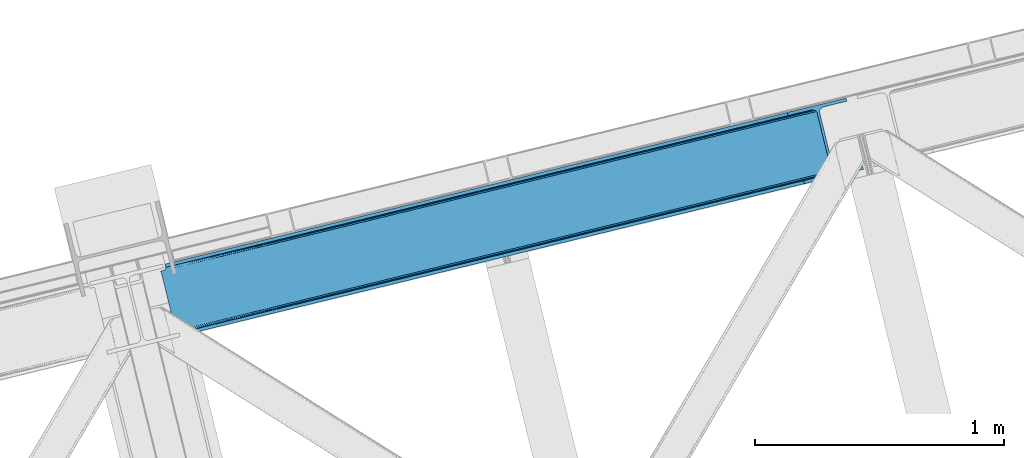
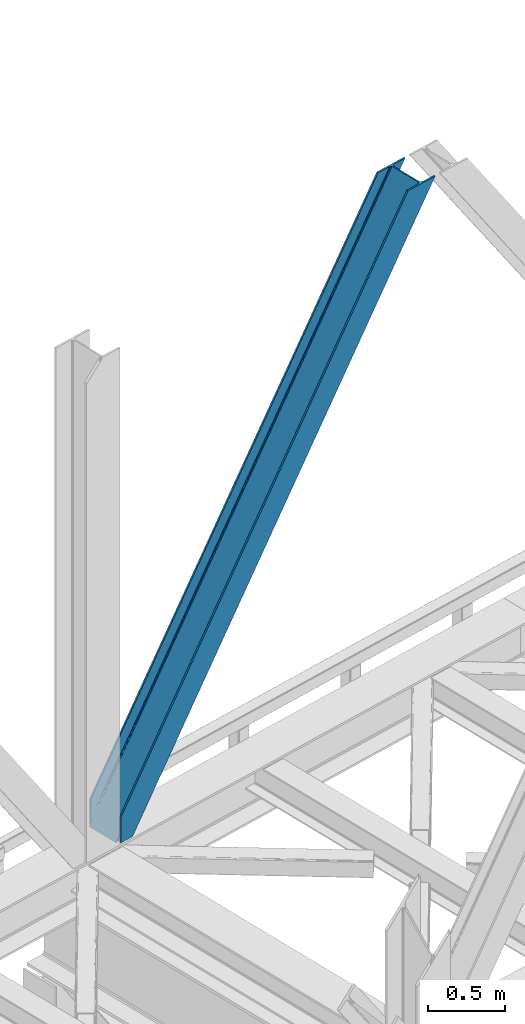
# One storey, part 33 of 92: 1 member.
"""IFC4 building model written with IfcOpenShell, lengths in millimetres."""

from ifc_helpers import new_model, entity, si_unit, converted_unit, derived_unit, direction, frame, origin, place, context, subcontext, project, spatial, triangles, type_object, element, save


model = new_model("IFC4")

# Units and contexts
model_context = context("Model", 3, precision=0.01, world=origin(), true_north=direction((6.12303176911189e-17, 1.0)))
plan_context = context("Plan", 3, precision=0.01, world=origin(), true_north=direction((6.12303176911189e-17, 1.0)))
body_context = subcontext(model_context, "Body", "Model", "MODEL_VIEW")
ifc_project = project(units=[si_unit("LENGTHUNIT", "METRE", prefix="MILLI"), si_unit("AREAUNIT", "SQUARE_METRE"), si_unit("VOLUMEUNIT", "CUBIC_METRE"), converted_unit("PLANEANGLEUNIT", "DEGREE", entity("IfcRatioMeasure", 0.0174532925199433), si_unit("PLANEANGLEUNIT", "RADIAN"), dimensions=[0, 0, 0, 0, 0, 0, 0]), si_unit("MASSUNIT", "GRAM", prefix="KILO"), derived_unit("MASSDENSITYUNIT", [(si_unit("MASSUNIT", "GRAM", prefix="KILO"), 1), (si_unit("LENGTHUNIT", "METRE"), -3)]), derived_unit("MOMENTOFINERTIAUNIT", [(si_unit("LENGTHUNIT", "METRE"), 4)]), si_unit("TIMEUNIT", "SECOND"), si_unit("FREQUENCYUNIT", "HERTZ"), si_unit("THERMODYNAMICTEMPERATUREUNIT", "DEGREE_CELSIUS"), derived_unit("THERMALTRANSMITTANCEUNIT", [(si_unit("MASSUNIT", "GRAM", prefix="KILO"), 1), (si_unit("THERMODYNAMICTEMPERATUREUNIT", "KELVIN"), -1), (si_unit("TIMEUNIT", "SECOND"), -3)]), derived_unit("VOLUMETRICFLOWRATEUNIT", [(si_unit("LENGTHUNIT", "METRE"), 3), (si_unit("TIMEUNIT", "SECOND"), -1)]), derived_unit("MASSFLOWRATEUNIT", [(si_unit("MASSUNIT", "GRAM", prefix="KILO"), 1), (si_unit("TIMEUNIT", "SECOND"), -1)]), derived_unit("ROTATIONALFREQUENCYUNIT", [(si_unit("TIMEUNIT", "SECOND"), -1)]), si_unit("ELECTRICCURRENTUNIT", "AMPERE"), si_unit("ELECTRICVOLTAGEUNIT", "VOLT"), si_unit("POWERUNIT", "WATT"), si_unit("FORCEUNIT", "NEWTON", prefix="KILO"), si_unit("ILLUMINANCEUNIT", "LUX"), si_unit("LUMINOUSFLUXUNIT", "LUMEN"), si_unit("LUMINOUSINTENSITYUNIT", "CANDELA"), derived_unit("USERDEFINED", [(si_unit("MASSUNIT", "GRAM", prefix="KILO"), -1), (si_unit("LENGTHUNIT", "METRE"), -2), (si_unit("TIMEUNIT", "SECOND"), 3), (si_unit("LUMINOUSFLUXUNIT", "LUMEN"), 1)]), derived_unit("LINEARVELOCITYUNIT", [(si_unit("LENGTHUNIT", "METRE"), 1), (si_unit("TIMEUNIT", "SECOND"), -1)]), si_unit("PRESSUREUNIT", "PASCAL"), derived_unit("USERDEFINED", [(si_unit("LENGTHUNIT", "METRE"), -2), (si_unit("MASSUNIT", "GRAM", prefix="KILO"), 1), (si_unit("TIMEUNIT", "SECOND"), -2)]), derived_unit("LINEARFORCEUNIT", [(si_unit("MASSUNIT", "GRAM", prefix="KILO"), 1), (si_unit("LENGTHUNIT", "METRE"), 1), (si_unit("TIMEUNIT", "SECOND"), -2), (si_unit("LENGTHUNIT", "METRE"), -1)]), derived_unit("PLANARFORCEUNIT", [(si_unit("MASSUNIT", "GRAM", prefix="KILO"), 1), (si_unit("LENGTHUNIT", "METRE"), 1), (si_unit("TIMEUNIT", "SECOND"), -2), (si_unit("LENGTHUNIT", "METRE"), -2)])], contexts=[model_context, plan_context])

# Site, building, storey
site_placement = place(None, origin())
site = spatial("IfcSite", under=ifc_project, at=site_placement, CompositionType="ELEMENT")
building_placement = place(site_placement, origin())
building = spatial("IfcBuilding", under=site, at=building_placement, CompositionType="ELEMENT")
storey_placement = place(building_placement, frame((0.0, 0.0, 15900.0)))
storey = spatial("IfcBuildingStorey", under=building, at=storey_placement, Name="05", CompositionType="ELEMENT", Elevation=15900.0)

# Member
member_type = type_object("IfcMemberType", PredefinedType="BRACE")
member_placement = place(storey_placement, frame((-55077.68, 7236.11, 3695.0)))
element("IfcMember", 1, at=member_placement, inside=storey, type_object=member_type, ObjectType="Steel Vertical Brace", PredefinedType="BRACE", context=body_context, shape_type="Tessellation", body=[
    triangles([(58.5731689453096, 24.8409255981442, 0.0), (60.4660766601592, 17.0687255859375, 0.0), (59.1126708984375, 17.8820480346676, 0.781347656247817), (58.9684936523408, 16.7042129516594, 1.0697021484375), (71.428198242189, 19.7406555175776, 19.5569458007813), (71.428198242189, 19.7406555175776, 0.0), (499.29045410156, 119.170051574707, 658.75048828125), (75.71630859375, 19.9243652343748, 26.4030395507798), (79.7486206054673, 18.4529434204096, 34.3676696777329), (501.02058105469, 125.602798461914, 656.525042724606), (81.3299194335923, 17.2873168945307, 38.5441589355469), (2694.2401977539, 660.223654174804, 3911.00081176758), (2694.23089599609, 667.310430908203, 3911.00081176758), (2268.13132324219, 563.444677734375, 3278.7231262207), (2268.67082519531, 556.485800170898, 3279.50447387695), (2691.01248779297, 653.425231933594, 3911.00081176758), (2266.94069824219, 550.053053283691, 3281.72759399414), (2685.03145751953, 647.951147460937, 3911.00081176758), (2263.20139160156, 545.12544708252, 3285.05529785156), (2677.20867919922, 644.635070800781, 3911.00081176758), (2258.02496337891, 542.454098510742, 3288.98063964843), (490.379370117189, 111.571678161621, 666.003533935545), (495.551147460938, 114.243026733398, 662.07819213867), (84.4413574218779, 12.6195785522459, 63.6403015136711), (83.9065063476592, 13.9003143310547, 51.2480346679658), (82.7484374999985, 15.426383972168, 45.5251281738274), (500.485729980472, 132.561676025391, 655.74602050781), (942.933142089845, 233.32354888916, 1312.27106323242), (942.398291015626, 240.282426452636, 1311.48971557617), (1384.845703125, 341.044299316406, 1968.01475830078), (1384.31085205078, 348.003176879883, 1967.23341064453), (1826.75826416015, 448.765049743653, 2623.75845336914), (1826.22341308594, 455.723927307129, 2622.97710571289), (941.203015136722, 226.891383361816, 1314.49418334961), (1383.11557617188, 334.611552429199, 1970.23787841797), (1825.02813720703, 442.332302856445, 2625.98389892578), (937.463708496092, 221.963777160644, 1317.82188720703), (1379.37626953125, 329.68452758789, 1973.56790771484), (1821.28883056641, 437.405278015137, 2629.3116027832), (932.291931152344, 219.291847229004, 1321.74955444336), (1374.2044921875, 327.013179016113, 1977.49324951172), (1816.11240234375, 434.733348083496, 2633.23694458008), (84.4413574218779, 12.6195785522459, 200.055230712889), (2585.27940673828, 622.225392150879, 3911.00081176758), (1329.12817382813, 574.374824523926, 1967.23341064453), (2639.05286865235, 893.682078552246, 3911.00081176758), (2212.95329589843, 789.816325378418, 3278.7231262207), (1771.04073486328, 682.095574951171, 2622.97710571289), (887.21561279297, 466.654074096679, 1311.48971557617), (445.303051757815, 358.933323669434, 655.74602050781), (3.39049072265334, 251.212573242187, 0.0), (2588.35828857422, 609.595349121094, 3911.00081176758), (84.7204101562529, 11.6585906982418, 200.120343017577), (87.5620971679673, 0.0, 200.120343017577), (87.5620971679673, 0.0, 0.0), (84.7204101562529, 11.6585906982418, 0.0), (72.8095092773438, 19.9854080200193, 0.0), (75.71630859375, 19.9243652343748, 3.35328369140552), (79.7486206054673, 18.4529434204096, 5.67639770507594), (77.6138671875015, 19.455207824707, 4.89272460937354), (81.3299194335923, 17.2873168945307, 5.12991943359157), (82.9112182617173, 15.5502136230461, 2.42078247070094), (83.5158325195298, 14.6316650390618, 0.0), (189.179150390628, 24.7705810546868, 0.0), (2824.8368774414, 667.240086364746, 3911.00081176758), (85.7296508789077, 14.7066604614256, 0.0), (94.1709960937515, 14.9915267944334, 0.0), (186.100268554685, 37.4006240844719, 0.0), (2821.75799560547, 679.870129394531, 3911.00081176758), (1408.54193115234, 335.383598327637, 1950.37164916992), (2299.97124023437, 552.67847442627, 3273.1420715332), (1854.2542602539, 444.031036376953, 2611.75686035156), (2729.82872314453, 657.461032104492, 3911.00081176758), (962.829602050784, 226.73616027832, 1288.98643798828), (517.112622070315, 118.088722229004, 627.598901367186), (501.20661621094, 125.647563171387, 637.077392578125), (72.1583862304688, 21.124291992187, 0.0), (505.704016113283, 120.733909606934, 634.854272460936), (498.481201171875, 132.073333740234, 637.858740234373), (511.289721679685, 118.079420471191, 631.526568603513), (2721.35947265625, 656.806420898437, 3911.00081176758), (2294.14368896485, 552.668591308594, 3277.06973876953), (2713.52739257812, 658.914431762695, 3911.00081176758), (2288.55798339844, 555.323661804199, 3280.39744262695), (2707.53240966797, 663.462991333007, 3911.00081176758), (2284.0605834961, 560.237896728516, 3282.62056274414), (2704.2814453125, 669.76028137207, 3911.00081176758), (2281.33516845703, 566.6630859375, 3283.40191040039), (68.6237182617188, 27.290776062011, 0.0), (957.006701660153, 226.726277160645, 1292.91177978515), (1402.71903076172, 335.373715209961, 1954.2969909668), (1848.43135986328, 444.02173461914, 2615.68220214844), (951.420996093751, 229.38134765625, 1296.23948364258), (1397.13332519531, 338.028785705566, 1957.62469482422), (1842.84565429688, 446.676223754883, 2619.01223144531), (946.9189453125, 234.295582580567, 1298.46260375976), (1392.63592529297, 342.943020629883, 1959.85014038086), (1838.34825439453, 451.589877319336, 2621.2353515625), (944.193530273435, 240.720771789551, 1299.24395141601), (1389.9105102539, 349.368209838867, 1960.63148803711), (1835.62283935547, 458.015647888184, 2622.01669921875), (1780.44481201172, 684.387295532227, 2622.01669921875), (1334.72783203125, 575.73985748291, 1960.63148803711), (2649.09876708985, 896.131929016113, 3911.00081176758), (2226.15714111328, 793.034733581543, 3283.40191040039), (889.015502929688, 467.092419433594, 1299.24395141601), (443.303173828128, 358.444981384278, 637.858740234373), (13.4410400390625, 253.662423706054, 0.0), (1.49758300781104, 258.985354614258, 0.0), (12.4597045898408, 261.657284545899, 0.0), (13.7433471679688, 260.764315795898, 0.0), (13.7991577148423, 262.075863647461, 0.0), (0.0, 258.620260620117, 1.0697021484375), (12.4597045898408, 261.657284545899, 19.5569458007813), (0.665075683595205, 257.638925170898, 0.781347656247817), (438.080236816408, 370.273329162597, 658.75048828125), (432.494531249999, 372.92781829834, 662.07819213867), (20.8498901367202, 272.585105895996, 51.2480346679658), (20.7243164062529, 270.661386108398, 44.4996093749978), (442.57763671875, 365.359675598144, 656.525042724606), (16.3524902343779, 263.467639160156, 26.4030395507798), (19.822045898436, 268.183049011231, 38.2720825195283), (19.254638671875, 266.629655456542, 34.3676696777329), (426.671630859375, 372.919097900391, 666.003533935545), (20.733618164064, 273.966998291015, 63.6403015136711), (2621.97484130859, 906.636520385742, 3911.00081176758), (2613.50559082031, 905.982490539551, 3911.00081176758), (2200.14477539063, 803.810820007324, 3285.05529785156), (2194.321875, 803.801518249512, 3288.98063964843), (2629.80227050781, 904.528509521484, 3911.00081176758), (2205.73048095703, 801.156330871582, 3281.72759399414), (2635.79725341797, 899.979949951172, 3911.00081176758), (2210.22788085938, 796.242095947266, 3279.50447387695), (874.407092285153, 480.648568725585, 1317.82188720703), (868.58419189453, 480.639266967773, 1321.74955444336), (1316.31965332032, 588.369319152832, 1973.56790771484), (1310.49675292968, 588.360017395019, 1977.49324951172), (1758.23221435547, 696.090069580078, 2629.3116027832), (1752.40931396485, 696.080767822265, 2633.23694458008), (879.992797851563, 477.994079589844, 1314.49418334961), (1321.90535888672, 585.714830017089, 1970.23787841797), (1763.81791992187, 693.435580444336, 2625.98389892578), (884.490197753905, 473.079844665527, 1312.27106323242), (1326.40275878906, 580.801176452636, 1968.01475830078), (1768.31531982422, 688.521345520019, 2623.75845336914), (2521.57166748047, 883.572811889649, 3911.00081176758), (20.733618164064, 273.966998291015, 200.055230712889), (16.3524902343779, 263.467639160156, 3.35328369140552), (19.254638671875, 266.629655456542, 5.67639770507594), (17.8221679687485, 264.760583496093, 4.89505004882813), (20.1197021484404, 268.390594482422, 5.12991943359157), (20.7243164062529, 270.661386108398, 2.42078247070094), (20.5429321289048, 274.949496459961, 0.0), (20.8405883789092, 271.75492401123, 0.0), (20.5429321289048, 274.949496459961, 200.120343017577), (22.8404663085967, 272.707191467285, 0.0), (448.233105468753, 376.764212036132, 631.526568603513), (444.493798828124, 371.837187194824, 634.854272460936), (30.4632568359375, 276.338946533203, 0.0), (442.763671875, 365.404440307617, 637.077392578125), (2649.08946533203, 903.219868469238, 3911.00081176758), (2225.61763916015, 799.994192504882, 3282.62056274414), (2652.32182617187, 910.017709350585, 3911.00081176758), (2227.35241699219, 806.426939392089, 3280.39744262695), (2658.30285644531, 915.491793823242, 3911.00081176758), (2231.08707275391, 811.353964233398, 3277.06973876953), (2666.12098388672, 918.808451843262, 3911.00081176758), (2236.26350097657, 814.025894165039, 3273.1420715332), (453.409533691403, 379.43556060791, 627.598901367186), (888.47600097656, 474.051878356933, 1298.46260375976), (1334.19298095703, 582.69931640625, 1959.85014038086), (1779.9053100586, 691.346754455566, 2621.2353515625), (890.210778808592, 480.48462524414, 1296.23948364258), (1335.92310791016, 589.132063293457, 1957.62469482422), (1781.63543701172, 697.779501342773, 2619.01223144531), (893.945434570313, 485.411650085449, 1292.91177978515), (1339.66241455078, 594.059088134765, 1954.2969909668), (1785.37474365234, 702.706526184082, 2615.68220214844), (899.12186279297, 488.08358001709, 1288.98643798828), (1344.83419189453, 596.731018066406, 1950.37164916992), (1790.551171875, 705.378456115723, 2611.75686035156), (2518.49278564453, 896.203436279297, 3911.00081176758), (17.7012451171904, 286.608087158203, 200.120343017577), (17.7012451171904, 286.608087158203, 0.0), (2754.97602539063, 953.847592163086, 3911.00081176758), (2758.05490722656, 941.217549133301, 3911.00081176758), (119.318298339844, 311.378086853028, 0.0), (122.392529296878, 298.748043823242, 0.0)], [[1, 2, 3], [4, 3, 2], [5, 4, 6], [2, 6, 4], [7, 8, 9], [10, 3, 5], [5, 7, 10], [5, 8, 7], [3, 4, 5], [9, 11, 7], [12, 13, 14], [14, 15, 12], [16, 12, 15], [15, 17, 16], [18, 16, 17], [17, 19, 18], [20, 18, 19], [19, 21, 20], [22, 23, 24], [25, 24, 23], [25, 7, 26], [25, 23, 7], [11, 26, 7], [10, 27, 1], [1, 3, 10], [28, 29, 27], [27, 10, 28], [30, 31, 28], [29, 28, 31], [32, 33, 31], [31, 30, 32], [15, 14, 33], [33, 32, 15], [34, 28, 7], [10, 7, 28], [35, 30, 34], [28, 34, 30], [36, 32, 30], [30, 35, 36], [17, 15, 36], [32, 36, 15], [37, 34, 23], [7, 23, 34], [38, 35, 34], [34, 37, 38], [39, 36, 38], [35, 38, 36], [19, 17, 39], [36, 39, 17], [40, 37, 23], [23, 22, 40], [41, 38, 40], [37, 40, 38], [42, 39, 41], [38, 41, 39], [21, 19, 42], [39, 42, 19], [41, 43, 44], [44, 21, 42], [21, 44, 20], [42, 41, 44], [43, 41, 40], [40, 22, 43], [24, 43, 22], [33, 45, 31], [13, 46, 47], [48, 14, 47], [45, 33, 48], [47, 14, 13], [48, 33, 14], [31, 49, 29], [49, 50, 27], [49, 31, 45], [51, 1, 50], [49, 27, 29], [50, 1, 27], [52, 53, 54], [52, 44, 53], [43, 53, 44], [55, 54, 53], [53, 56, 55], [5, 6, 57], [58, 8, 5], [59, 9, 8], [8, 58, 60], [61, 26, 11], [61, 11, 9], [9, 59, 61], [56, 26, 62], [56, 25, 26], [56, 53, 24], [43, 24, 53], [24, 25, 56], [62, 63, 56], [61, 62, 26], [8, 60, 59], [57, 58, 5], [52, 64, 65], [64, 52, 54], [55, 64, 54], [66, 67, 56], [64, 67, 68], [67, 64, 55], [55, 56, 67], [56, 63, 66], [69, 65, 68], [64, 68, 65], [70, 69, 68], [71, 69, 72], [71, 73, 69], [70, 72, 69], [68, 74, 70], [75, 74, 68], [68, 67, 75], [76, 60, 58], [76, 59, 60], [58, 77, 76], [58, 57, 77], [76, 78, 61], [61, 59, 76], [79, 76, 77], [80, 75, 67], [80, 62, 61], [80, 66, 62], [66, 63, 62], [61, 78, 80], [67, 66, 80], [81, 73, 71], [71, 82, 81], [83, 81, 82], [82, 84, 83], [85, 83, 84], [84, 86, 85], [87, 85, 86], [86, 88, 87], [77, 89, 79], [90, 74, 75], [75, 80, 90], [91, 70, 90], [74, 90, 70], [92, 72, 91], [70, 91, 72], [82, 71, 92], [72, 92, 71], [93, 90, 78], [80, 78, 90], [94, 91, 93], [90, 93, 91], [95, 92, 91], [91, 94, 95], [84, 82, 95], [92, 95, 82], [96, 93, 78], [78, 76, 96], [97, 94, 93], [93, 96, 97], [98, 95, 94], [94, 97, 98], [86, 84, 95], [95, 98, 86], [99, 96, 79], [76, 79, 96], [100, 97, 99], [96, 99, 97], [101, 98, 100], [97, 100, 98], [88, 86, 101], [98, 101, 86], [102, 100, 103], [104, 87, 88], [101, 105, 88], [100, 102, 101], [88, 105, 104], [101, 102, 105], [103, 99, 106], [99, 79, 107], [99, 103, 100], [89, 108, 79], [99, 107, 106], [79, 108, 107], [108, 109, 110], [51, 108, 89], [108, 51, 109], [89, 1, 51], [2, 89, 6], [89, 2, 1], [77, 6, 89], [108, 110, 111], [112, 111, 110], [57, 6, 77], [113, 114, 110], [110, 109, 113], [109, 51, 115], [115, 113, 109], [116, 117, 118], [118, 119, 116], [120, 121, 114], [114, 115, 120], [114, 113, 115], [120, 116, 122], [122, 123, 120], [123, 121, 120], [119, 122, 116], [117, 124, 125], [125, 118, 117], [126, 127, 128], [129, 128, 127], [130, 126, 131], [128, 131, 126], [132, 130, 133], [131, 133, 130], [46, 132, 47], [133, 47, 132], [134, 135, 117], [124, 117, 135], [136, 137, 135], [135, 134, 136], [138, 139, 137], [137, 136, 138], [128, 129, 139], [139, 138, 128], [140, 134, 116], [117, 116, 134], [141, 136, 140], [134, 140, 136], [142, 138, 136], [136, 141, 142], [131, 128, 138], [138, 142, 131], [143, 140, 116], [116, 120, 143], [144, 141, 140], [140, 143, 144], [145, 142, 144], [141, 144, 142], [133, 131, 142], [142, 145, 133], [50, 120, 51], [115, 51, 120], [49, 143, 50], [120, 50, 143], [45, 144, 143], [143, 49, 45], [48, 145, 45], [144, 45, 145], [47, 133, 48], [145, 48, 133], [146, 147, 137], [137, 139, 146], [139, 129, 146], [127, 146, 129], [135, 137, 147], [147, 125, 124], [124, 135, 147], [114, 148, 112], [112, 110, 114], [149, 150, 121], [121, 123, 149], [151, 149, 123], [123, 122, 151], [119, 152, 151], [153, 118, 125], [153, 154, 152], [152, 119, 153], [119, 118, 153], [155, 153, 125], [125, 147, 155], [122, 119, 151], [150, 148, 121], [114, 121, 148], [156, 157, 152], [157, 158, 151], [151, 152, 157], [157, 156, 159], [107, 108, 111], [160, 149, 151], [160, 111, 148], [148, 150, 160], [150, 149, 160], [111, 112, 148], [151, 158, 160], [111, 160, 107], [161, 104, 162], [105, 162, 104], [163, 161, 164], [162, 164, 161], [165, 163, 166], [164, 166, 163], [167, 165, 168], [166, 168, 165], [159, 169, 157], [152, 154, 156], [170, 106, 107], [107, 160, 170], [171, 103, 170], [106, 170, 103], [172, 102, 103], [103, 171, 172], [162, 105, 102], [102, 172, 162], [173, 170, 158], [160, 158, 170], [174, 171, 173], [170, 173, 171], [175, 172, 174], [171, 174, 172], [164, 162, 175], [172, 175, 162], [176, 173, 158], [158, 157, 176], [177, 174, 173], [173, 176, 177], [178, 175, 174], [174, 177, 178], [166, 164, 175], [175, 178, 166], [179, 176, 169], [157, 169, 176], [180, 177, 176], [176, 179, 180], [181, 178, 177], [177, 180, 181], [168, 166, 178], [178, 181, 168], [182, 155, 146], [155, 182, 183], [155, 147, 146], [153, 155, 184], [183, 184, 155], [46, 13, 104], [16, 18, 81], [20, 52, 65], [44, 52, 20], [18, 20, 73], [13, 12, 85], [12, 16, 83], [130, 165, 126], [182, 127, 185], [127, 126, 167], [182, 146, 127], [130, 132, 163], [132, 46, 161], [104, 13, 87], [73, 81, 18], [85, 12, 83], [81, 83, 16], [85, 87, 13], [65, 73, 20], [65, 69, 73], [167, 126, 165], [163, 132, 161], [104, 161, 46], [163, 165, 130], [167, 185, 127], [185, 167, 186], [159, 156, 153], [187, 159, 184], [159, 187, 188], [154, 153, 156], [153, 184, 159], [182, 187, 183], [182, 185, 187], [187, 184, 183], [186, 180, 188], [181, 186, 168], [186, 181, 180], [186, 167, 168], [179, 188, 180], [159, 188, 169], [179, 169, 188], [185, 186, 188], [188, 187, 185]]),
])

save(model, "model.ifc")
